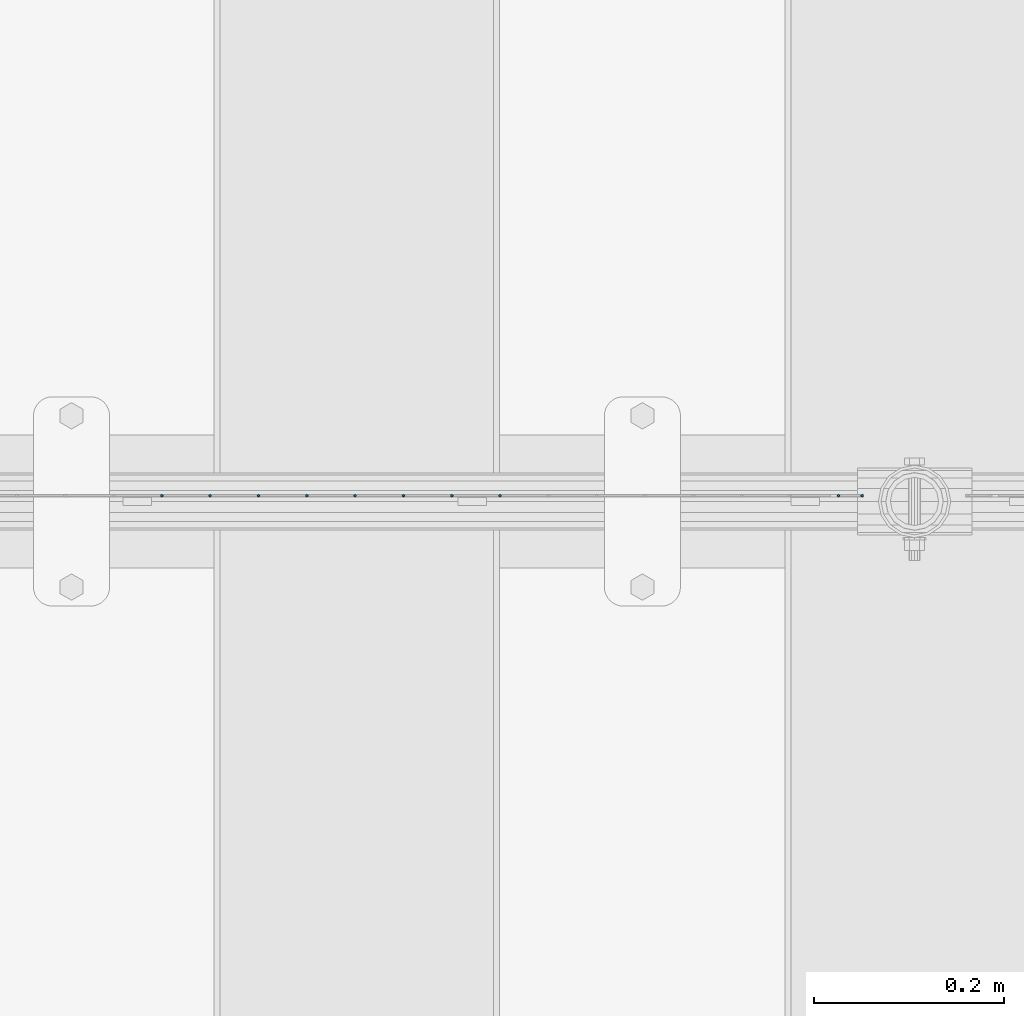
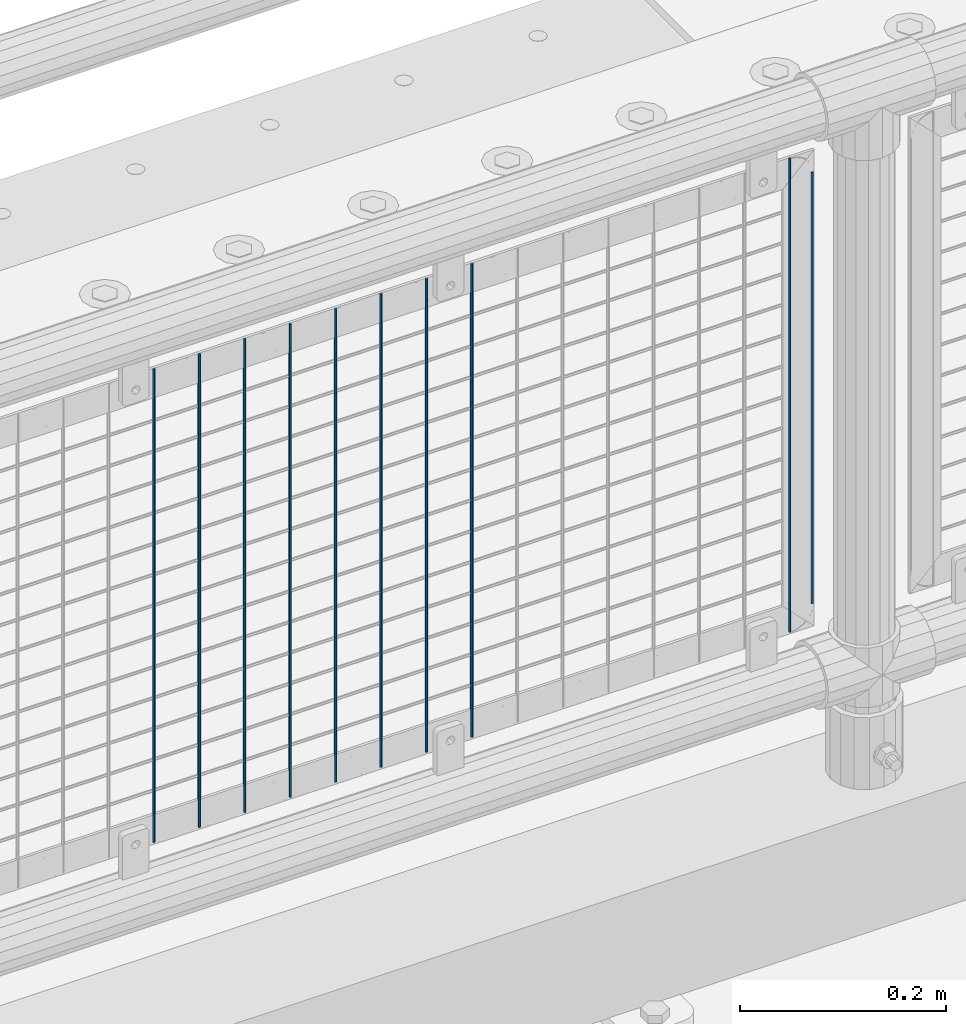
# One storey, part 80 of 242: 10 columns.
"""IFC2X3 building model written with IfcOpenShell, lengths in millimetres."""

from ifc_helpers import new_model, si_unit, frame, origin_with_axes, place, context, subcontext, project, spatial, faceted_brep, material, type_object, element, save


model = new_model("IFC2X3")

# Units and contexts
model_context = context("Model", 3, precision=1e-05, world=origin_with_axes())
body_context = subcontext(model_context, "Body", "Model", "MODEL_VIEW")
ifc_project = project(units=[si_unit("LENGTHUNIT", "METRE", prefix="MILLI"), si_unit("AREAUNIT", "SQUARE_METRE"), si_unit("VOLUMEUNIT", "CUBIC_METRE"), si_unit("MASSUNIT", "GRAM", prefix="KILO"), si_unit("TIMEUNIT", "SECOND"), si_unit("PLANEANGLEUNIT", "RADIAN"), si_unit("SOLIDANGLEUNIT", "STERADIAN"), si_unit("THERMODYNAMICTEMPERATUREUNIT", "DEGREE_CELSIUS"), si_unit("LUMINOUSINTENSITYUNIT", "LUMEN")], contexts=[model_context])

# Site, building, storey
site_placement = place(None, origin_with_axes())
site = spatial("IfcSite", under=ifc_project, at=site_placement, CompositionType="ELEMENT")
building_placement = place(site_placement, origin_with_axes())
building = spatial("IfcBuilding", under=site, at=building_placement, Name="Standard", CompositionType="ELEMENT")
storey_placement = place(building_placement, origin_with_axes())
storey = spatial("IfcBuildingStorey", under=building, at=storey_placement, Name="Undefined", CompositionType="ELEMENT", Elevation=0.0)

# Columns
ifc_material = material(Name="Misc_Undefined")
column_type = type_object("IfcColumnType", Name="D3", PredefinedType="NOTDEFINED")
for number, where, z_axis, x_axis in (
    (1, (-34099.554, -19329.5, 353.02), (-1.0, 0.0, 0.0), (0.0, 0.0, 1.0)),
    (2, (-33744.003, -19329.5, 353.02), (-1.0, 0.0, 0.0), (0.0, 0.0, 1.0)),
    (3, (-34150.347, -19329.5, 353.02), (-1.0, 0.0, 0.0), (0.0, 0.0, 1.0)),
    (4, (-34201.14, -19329.5, 353.02), (-1.0, 0.0, 0.0), (0.0, 0.0, 1.0)),
    (5, (-34251.933, -19329.5, 353.02), (-1.0, 0.0, 0.0), (0.0, 0.0, 1.0)),
    (6, (-34302.726, -19329.5, 353.02), (-1.0, 0.0, 0.0), (0.0, 0.0, 1.0)),
    (7, (-34353.519, -19329.5, 353.02), (-1.0, 0.0, 0.0), (0.0, 0.0, 1.0)),
    (8, (-34404.312, -19329.5, 353.02), (-1.0, 0.0, 0.0), (0.0, 0.0, 1.0)),
    (9, (-34455.105, -19329.5, 353.02), (-1.0, 0.0, 0.0), (0.0, 0.0, 1.0)),
):
    element("IfcColumn", number, at=place(storey_placement, frame(where, z_axis=z_axis, x_axis=x_axis)), inside=storey, type_object=column_type, material=ifc_material, ObjectType="D3", context=body_context, shape_type="Brep", body=[
        faceted_brep([(0.0, -1.50000000000364, 0.0), (-3.63797880709171e-12, -0.750000000003638, -1.29903810567669), (560.0, -0.75, -1.29903810567703), (560.0, -1.5, 0.0), (0.0, 0.749999999996362, -1.29903810567669), (560.0, 0.75, -1.29903810567703), (-3.63797880709171e-12, 1.49999999999636, 0.0), (560.0, 1.5, 0.0), (0.0, 0.749999999996362, 1.29903810567669), (560.0, 0.75, 1.29903810567703), (-3.63797880709171e-12, -0.750000000003638, 1.29903810567669), (560.0, -0.75, 1.29903810567703)], [[[0, 1, 2, 3]], [[1, 4, 5, 2]], [[4, 6, 7, 5]], [[6, 8, 9, 7]], [[8, 10, 11, 9]], [[10, 0, 3, 11]], [[5, 7, 9, 11, 3, 2]], [[10, 8, 6, 4, 1, 0]]]),
    ])
column_placement = place(storey_placement, frame((-33719.0, -19329.5, 378.02), z_axis=(-1.0, 0.0, 0.0), x_axis=(0.0, 0.0, 1.0)))
element("IfcColumn", 10, at=column_placement, inside=storey, type_object=column_type, material=ifc_material, ObjectType="D3", context=body_context, shape_type="Brep", body=[
    faceted_brep([(0.0, -1.50000000000364, 0.0), (-3.63797880709171e-12, -0.750000000003638, -1.29903810567669), (510.0, -0.75, -1.29903810567703), (510.0, -1.5, 0.0), (0.0, 0.749999999996362, -1.29903810567669), (510.0, 0.75, -1.29903810567703), (-3.63797880709171e-12, 1.49999999999636, 0.0), (510.0, 1.5, 0.0), (0.0, 0.749999999996362, 1.29903810567669), (510.0, 0.75, 1.29903810567703), (-3.63797880709171e-12, -0.750000000003638, 1.29903810567669), (510.0, -0.75, 1.29903810567703)], [[[0, 1, 2, 3]], [[1, 4, 5, 2]], [[4, 6, 7, 5]], [[6, 8, 9, 7]], [[8, 10, 11, 9]], [[10, 0, 3, 11]], [[5, 7, 9, 11, 3, 2]], [[10, 8, 6, 4, 1, 0]]]),
])

save(model, "model.ifc")
